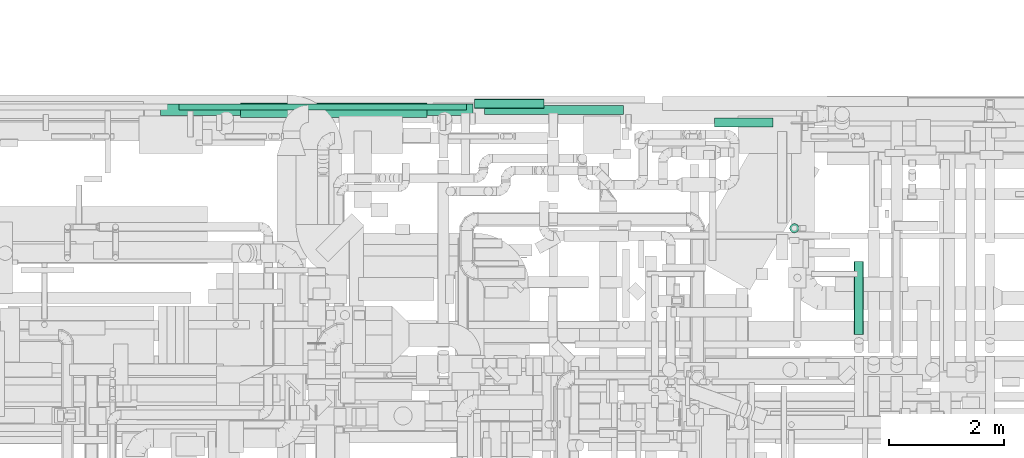
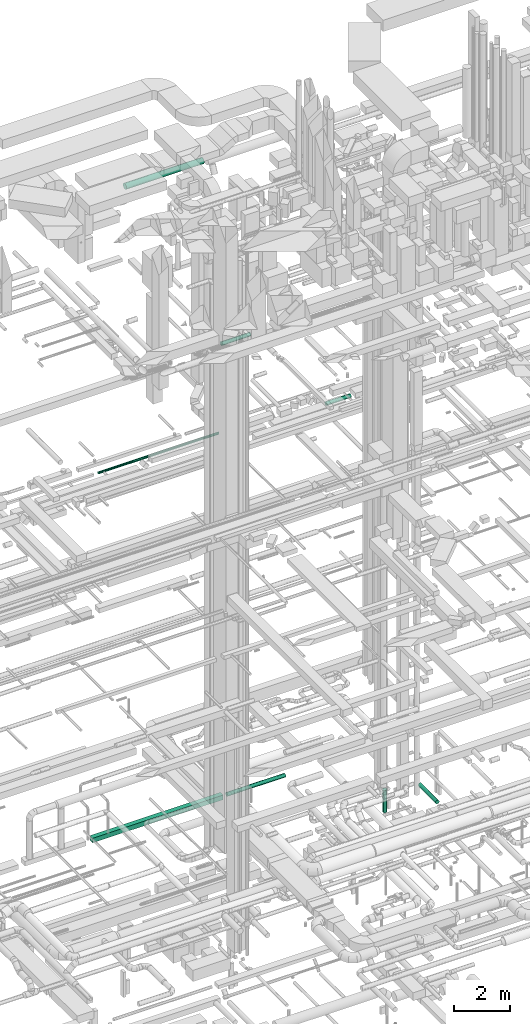
# One storey, part 75 of 337: 8 flow segments.
"""IFC2X3 building model written with IfcOpenShell, lengths in millimetres."""

from ifc_helpers import new_model, entity, si_unit, converted_unit, derived_unit, direction, frame, origin, origin_2d_with_axis, place, context, subcontext, project, spatial, rectangle, circle, extrude, type_object, element, save


model = new_model("IFC2X3")

# Units and contexts
model_context = context("Model", 3, precision=0.01, world=origin(), true_north=direction((6.12303176911189e-17, 1.0)))
body_context = subcontext(model_context, "Body", "Model", "MODEL_VIEW")
ifc_project = project(units=[si_unit("LENGTHUNIT", "METRE", prefix="MILLI"), si_unit("AREAUNIT", "SQUARE_METRE"), si_unit("VOLUMEUNIT", "CUBIC_METRE"), converted_unit("PLANEANGLEUNIT", "DEGREE", entity("IfcRatioMeasure", 0.0174532925199433), si_unit("PLANEANGLEUNIT", "RADIAN"), dimensions=[0, 0, 0, 0, 0, 0, 0]), si_unit("MASSUNIT", "GRAM", prefix="KILO"), derived_unit("MASSDENSITYUNIT", [(si_unit("MASSUNIT", "GRAM", prefix="KILO"), 1), (si_unit("LENGTHUNIT", "METRE"), -3)]), derived_unit("MOMENTOFINERTIAUNIT", [(si_unit("LENGTHUNIT", "METRE"), 4)]), si_unit("TIMEUNIT", "SECOND"), si_unit("FREQUENCYUNIT", "HERTZ"), si_unit("THERMODYNAMICTEMPERATUREUNIT", "DEGREE_CELSIUS"), derived_unit("THERMALTRANSMITTANCEUNIT", [(si_unit("MASSUNIT", "GRAM", prefix="KILO"), 1), (si_unit("THERMODYNAMICTEMPERATUREUNIT", "KELVIN"), -1), (si_unit("TIMEUNIT", "SECOND"), -3)]), derived_unit("VOLUMETRICFLOWRATEUNIT", [(si_unit("LENGTHUNIT", "METRE"), 3), (si_unit("TIMEUNIT", "SECOND"), -1)]), derived_unit("MASSFLOWRATEUNIT", [(si_unit("MASSUNIT", "GRAM", prefix="KILO"), 1), (si_unit("TIMEUNIT", "SECOND"), -1)]), derived_unit("ROTATIONALFREQUENCYUNIT", [(si_unit("TIMEUNIT", "SECOND"), -1)]), si_unit("ELECTRICCURRENTUNIT", "AMPERE"), si_unit("ELECTRICVOLTAGEUNIT", "VOLT"), si_unit("POWERUNIT", "WATT"), si_unit("FORCEUNIT", "NEWTON", prefix="KILO"), si_unit("ILLUMINANCEUNIT", "LUX"), si_unit("LUMINOUSFLUXUNIT", "LUMEN"), si_unit("LUMINOUSINTENSITYUNIT", "CANDELA"), derived_unit("USERDEFINED", [(si_unit("MASSUNIT", "GRAM", prefix="KILO"), -1), (si_unit("LENGTHUNIT", "METRE"), -2), (si_unit("TIMEUNIT", "SECOND"), 3), (si_unit("LUMINOUSFLUXUNIT", "LUMEN"), 1)]), derived_unit("LINEARVELOCITYUNIT", [(si_unit("LENGTHUNIT", "METRE"), 1), (si_unit("TIMEUNIT", "SECOND"), -1)]), si_unit("PRESSUREUNIT", "PASCAL"), derived_unit("USERDEFINED", [(si_unit("LENGTHUNIT", "METRE"), -2), (si_unit("MASSUNIT", "GRAM", prefix="KILO"), 1), (si_unit("TIMEUNIT", "SECOND"), -2)]), derived_unit("LINEARFORCEUNIT", [(si_unit("MASSUNIT", "GRAM", prefix="KILO"), 1), (si_unit("LENGTHUNIT", "METRE"), 1), (si_unit("TIMEUNIT", "SECOND"), -2), (si_unit("LENGTHUNIT", "METRE"), -1)]), derived_unit("PLANARFORCEUNIT", [(si_unit("MASSUNIT", "GRAM", prefix="KILO"), 1), (si_unit("LENGTHUNIT", "METRE"), 1), (si_unit("TIMEUNIT", "SECOND"), -2), (si_unit("LENGTHUNIT", "METRE"), -2)])], contexts=[model_context])

# Site, building, storey
site_placement = place(None, origin())
site = spatial("IfcSite", under=ifc_project, at=site_placement, CompositionType="ELEMENT")
building_placement = place(site_placement, origin())
building = spatial("IfcBuilding", under=site, at=building_placement, CompositionType="ELEMENT")
storey_placement = place(building_placement, origin())
storey = spatial("IfcBuildingStorey", under=building, at=storey_placement, CompositionType="ELEMENT", Elevation=0.0)

# Flow segments
duct_segment_type_1 = type_object("IfcDuctSegmentType", PredefinedType="NOTDEFINED")
flow_segment_1_placement = place(storey_placement, frame((44054.97, 19763.8, -700.0)))
element("IfcFlowSegment", 1, at=flow_segment_1_placement, inside=storey, type_object=duct_segment_type_1, context=body_context, shape_type="SweptSolid", body=[
    extrude(rectangle(XDim=5425.59736874995, YDim=199.999999999998, at=origin_2d_with_axis()), frame((2712.8, 100.0, 0.0)), (0.0, 0.0, 1.0), 200.0),
])
duct_segment_type_2 = type_object("IfcDuctSegmentType", PredefinedType="NOTDEFINED")
flow_segment_2_placement = place(storey_placement, frame((49680.57, 19782.2, -681.6)))
element("IfcFlowSegment", 2, at=flow_segment_2_placement, inside=storey, type_object=duct_segment_type_2, context=body_context, shape_type="SweptSolid", body=[
    extrude(circle(Radius=80.0, at=origin_2d_with_axis()), frame((0.0, 81.6, 81.6), z_axis=(1.0, 0.0, 0.0), x_axis=(0.0, -1.0, 0.0)), (0.0, 0.0, 1.0), 2415.18218124998),
])
flow_segment_3_placement = place(storey_placement, frame((54982.68, 17727.19, -1995.0)))
element("IfcFlowSegment", 3, at=flow_segment_3_placement, inside=storey, type_object=duct_segment_type_2, context=body_context, shape_type="SweptSolid", body=[
    extrude(circle(Radius=80.0, at=origin_2d_with_axis()), frame((81.6, 81.6, 0.0)), (0.0, 0.0, 1.0), 985.000024999986),
])
flow_segment_4_placement = place(storey_placement, frame((49509.92, 19888.5, 19110.32)))
element("IfcFlowSegment", 4, at=flow_segment_4_placement, inside=storey, type_object=duct_segment_type_2, context=body_context, shape_type="SweptSolid", body=[
    extrude(circle(Radius=80.0, at=origin_2d_with_axis()), frame((0.0, 81.6, 81.6), z_axis=(1.0, 0.0, 0.0), x_axis=(0.0, 1.0, 0.0)), (0.0, 0.0, 1.0), 1205.00000000001),
])
flow_segment_5_placement = place(storey_placement, frame((44372.01, 19862.29, 15298.4)))
element("IfcFlowSegment", 5, at=flow_segment_5_placement, inside=storey, type_object=duct_segment_type_2, context=body_context, shape_type="SweptSolid", body=[
    extrude(circle(Radius=50.0, at=origin_2d_with_axis()), frame((0.0, 51.6, 51.6), z_axis=(1.0, 0.0, 0.0), x_axis=(0.0, -1.0, 0.0)), (0.0, 0.0, 1.0), 5000.00000000001),
])
flow_segment_6_placement = place(storey_placement, frame((53673.97, 19564.2, 15218.4)))
element("IfcFlowSegment", 6, at=flow_segment_6_placement, inside=storey, type_object=duct_segment_type_2, context=body_context, shape_type="SweptSolid", body=[
    extrude(circle(Radius=80.0, at=origin_2d_with_axis()), frame((0.0, 81.6, 81.6), z_axis=(1.0, 0.0, 0.0), x_axis=(0.0, 1.0, 0.0)), (0.0, 0.0, 1.0), 1020.00000000005),
])
flow_segment_7_placement = place(storey_placement, frame((45445.7, 19732.39, 27473.4)))
element("IfcFlowSegment", 7, at=flow_segment_7_placement, inside=storey, type_object=duct_segment_type_2, context=body_context, shape_type="SweptSolid", body=[
    extrude(circle(Radius=125.0, at=origin_2d_with_axis()), frame((0.0, 126.6, 126.6), z_axis=(1.0, 0.0, 0.0), x_axis=(0.0, -1.0, 0.0)), (0.0, 0.0, 1.0), 3234.41051849907),
])
flow_segment_8_placement = place(storey_placement, frame((56103.94, 15964.15, -931.6)))
element("IfcFlowSegment", 8, at=flow_segment_8_placement, inside=storey, type_object=duct_segment_type_2, context=body_context, shape_type="SweptSolid", body=[
    extrude(circle(Radius=80.0, at=origin_2d_with_axis()), frame((81.6, 0.0, 81.6), z_axis=(0.0, 1.0, 0.0), x_axis=(-1.0, 0.0, 0.0)), (0.0, 0.0, 1.0), 1262.84722023848),
])

save(model, "model.ifc")
